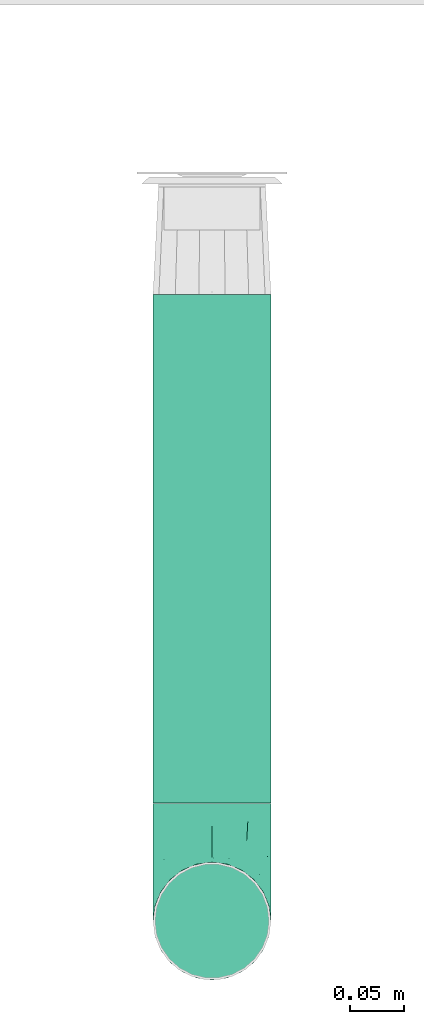
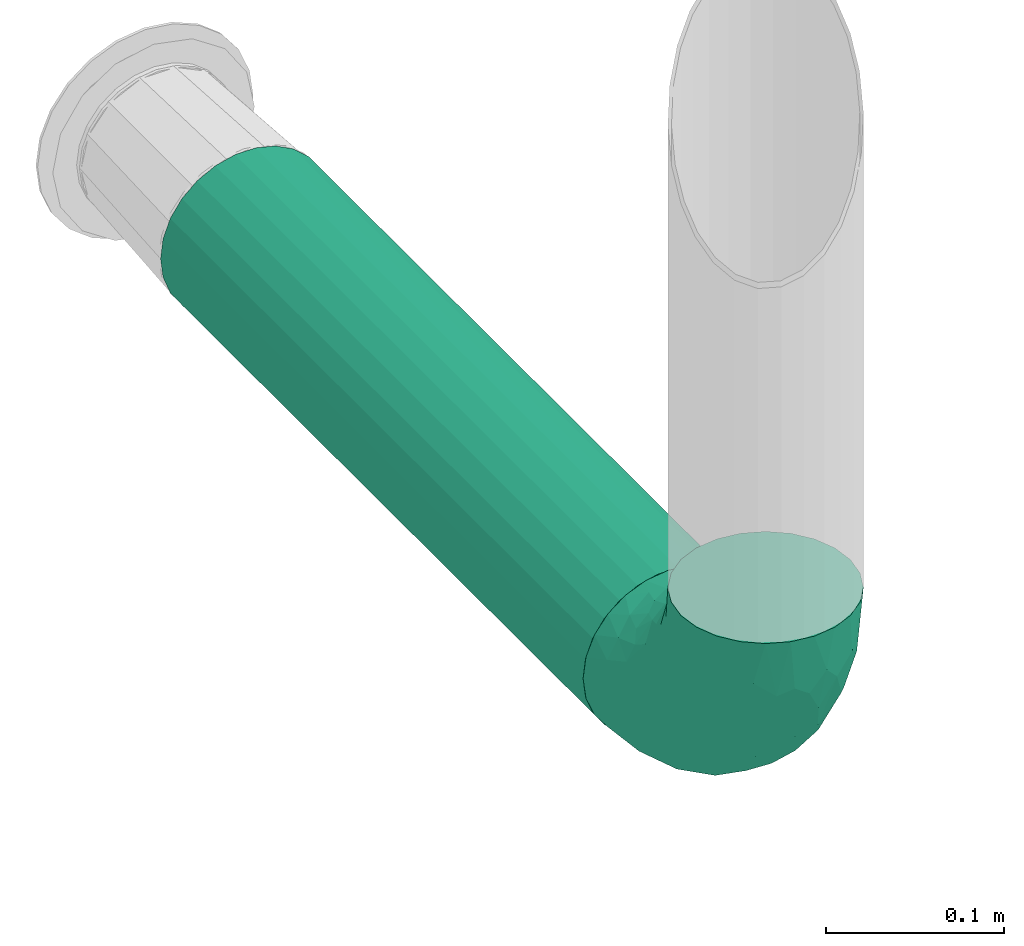
# One storey, part 66 of 123: 1 flow fitting, 1 flow segment.
"""IFC2X3 building model written with IfcOpenShell, lengths in millimetres."""

from ifc_helpers import new_model, entity, si_unit, converted_unit, derived_unit, direction, frame, origin_with_axes, origin_2d_with_axis, place, context, subcontext, project, spatial, hollow_circle, extrude, open_shell, surface_model, source, transform, mapped, material, layer, layer_set, layer_usage, type_object, element, save


model = new_model("IFC2X3")

# Units and contexts
model_context = context("Model", 3, precision=1e-05, world=origin_with_axes(), true_north=direction((0.0, 1.0)))
body_context = subcontext(model_context, "Body", "Model", "MODEL_VIEW")
ifc_project = project(units=[si_unit("AREAUNIT", "SQUARE_METRE"), si_unit("VOLUMEUNIT", "CUBIC_METRE", prefix="DECI"), si_unit("TIMEUNIT", "SECOND"), si_unit("THERMODYNAMICTEMPERATUREUNIT", "DEGREE_CELSIUS"), si_unit("PRESSUREUNIT", "PASCAL"), si_unit("MASSUNIT", "GRAM", prefix="KILO"), si_unit("LENGTHUNIT", "METRE", prefix="MILLI"), si_unit("POWERUNIT", "WATT"), si_unit("ELECTRICCURRENTUNIT", "AMPERE"), si_unit("ELECTRICVOLTAGEUNIT", "VOLT"), derived_unit("VOLUMETRICFLOWRATEUNIT", [(si_unit("VOLUMEUNIT", "CUBIC_METRE", prefix="DECI"), 1), (si_unit("TIMEUNIT", "SECOND"), -1)]), derived_unit("LINEARVELOCITYUNIT", [(si_unit("LENGTHUNIT", "METRE"), 1), (si_unit("TIMEUNIT", "SECOND"), -1)]), derived_unit("MASSDENSITYUNIT", [(si_unit("MASSUNIT", "GRAM", prefix="KILO"), 1), (si_unit("VOLUMEUNIT", "CUBIC_METRE"), -1)]), converted_unit("PLANEANGLEUNIT", "DEGREE", entity("IfcRatioMeasure", 0.01745), si_unit("PLANEANGLEUNIT", "RADIAN"), dimensions=[0, 0, 0, 0, 0, 0, 0])], contexts=[model_context])

# Site, building, storey
site_placement = place(None, origin_with_axes())
site = spatial("IfcSite", under=ifc_project, at=site_placement, CompositionType="ELEMENT")
building_placement = place(site_placement, origin_with_axes())
building = spatial("IfcBuilding", under=site, at=building_placement, Name="mc-building", CompositionType="ELEMENT")
storey_placement = place(building_placement, origin_with_axes())
storey = spatial("IfcBuildingStorey", under=building, at=storey_placement, Name="1. Korrus", CompositionType="ELEMENT", Elevation=0.0)

# Flow fitting
duct_fitting_type = type_object("IfcDuctFittingType", Name="BU", PredefinedType="BEND")
shared_shape_1 = source(origin_with_axes(), body_context, "Body", "SurfaceModel", [
    surface_model("IfcShellBasedSurfaceModel", [(-110.0, -38.89087, -38.89087), (-110.0, -55.0, 0.0), (-110.0, -27.5, -47.63139), (-110.0, -53.12592, -14.23505), (-110.0, -47.63139, -27.5), (-110.0, 47.63139, -27.5), (-110.0, 53.12592, 14.23505), (-110.0, 53.12592, -14.23505), (-110.0, -14.23505, -53.12592), (-110.0, 0.0, -55.0), (-110.0, 38.89087, -38.89087), (-110.0, 27.5, -47.63139), (-110.0, 14.23505, -53.12592), (-110.0, 55.0, 0.0), (-110.0, -53.12592, 14.23505), (-110.0, -47.63139, 27.5), (-110.0, -38.89087, 38.89087), (-110.0, 0.0, 55.0), (-110.0, -27.5, 47.63139), (-110.0, -14.23505, 53.12592), (-110.0, 38.89087, 38.89087), (-110.0, 47.63139, 27.5), (-110.0, 27.5, 47.63139), (-110.0, 14.23505, 53.12592), (0.0, -110.0, -55.0), (14.23505, -110.0, -53.12592), (-14.23505, -110.0, -53.12592), (-53.12592, -110.0, 14.23505), (-27.5, -110.0, -47.63139), (-47.63139, -110.0, -27.5), (-38.89087, -110.0, -38.89087), (55.0, -110.0, 0.0), (53.12592, -110.0, 14.23505), (38.89087, -110.0, -38.89087), (27.5, -110.0, -47.63139), (53.12592, -110.0, -14.23505), (47.63139, -110.0, -27.5), (-53.12592, -110.0, -14.23505), (-47.63139, -110.0, 27.5), (-38.89087, -110.0, 38.89087), (14.23505, -110.0, 53.12592), (-27.5, -110.0, 47.63139), (-14.23505, -110.0, 53.12592), (47.63139, -110.0, 27.5), (38.89087, -110.0, 38.89087), (27.5, -110.0, 47.63139), (0.0, -110.0, 55.0), (-55.0, -110.0, 0.0), (-60.44912, -32.56953, 51.94617), (-76.6405, -38.18013, 45.55988), (-64.21732, -48.68956, 43.63444), (-90.15553, -11.94394, 54.09138), (-76.00813, -5.38378, 55.0), (-70.18771, -18.55163, 54.03432), (-78.5998, -26.77405, 50.81338), (-93.27622, -45.77614, 33.48188), (-75.55424, -54.2118, 32.41257), (-96.12334, -22.13664, 50.81337), (-32.04182, -59.64019, 52.24446), (-18.36258, -70.48427, 54.04484), (-21.00813, -45.34362, 55.0), (-63.60674, -66.07878, 29.97482), (-74.66383, -63.08407, 19.92123), (-63.88653, -74.77858, 17.99134), (-93.11138, -56.59448, 10.50359), (-99.597, -52.72185, 18.52927), (-98.21577, -57.34403, 0.0), (-53.42855, -92.60092, 21.04759), (-88.54852, -54.8376, 21.04759), (-5.38378, -76.00813, 55.0), (-11.86161, -90.23965, 54.10313), (-56.64619, -93.12774, 10.22088), (-57.34403, -98.21577, 0.0), (-44.60838, -44.60838, 52.13415), (-45.34362, -21.00813, 55.0), (-92.68484, -35.46673, 43.63443), (-22.25266, -95.40765, 50.81337), (-27.23711, -77.39884, 50.81337), (-43.70931, -69.58671, 44.47149), (-35.97783, -90.61597, 43.63443), (-58.67786, -84.31125, 16.04456), (-57.2828, -79.3123, 24.9774), (-82.93277, -60.36161, 12.91784), (-49.88337, -54.51816, 47.224), (-74.57753, -66.83759, 9.55742), (-45.35812, -94.97281, 33.48188), (-59.18663, -88.95241, 0.0), (-51.517, -78.6292, 33.48188), (-65.14788, -80.03077, 0.0), (-56.45322, -62.06476, 39.63545), (-88.95241, -59.18663, 0.0), (-80.03077, -65.14788, 0.0), (-71.10913, -71.10913, 0.0), (-94.9309, -45.36788, -33.48188), (-93.11358, -56.60141, -10.46614), (-99.64997, -52.79499, -18.30015), (-79.99933, -46.56772, -37.92748), (-90.20425, -36.08686, -43.63443), (-45.34362, -21.00813, -55.0), (-72.75364, -19.68651, -53.60527), (-76.00813, -5.38378, -55.0), (-21.00813, -45.34362, -55.0), (-5.38378, -76.00813, -55.0), (-21.91957, -65.12078, -53.85897), (-35.41876, -92.89265, -43.63443), (-91.10309, -11.02766, -54.21832), (-45.77614, -93.27622, -33.48188), (-90.50474, -23.21022, -50.81337), (-70.92854, -33.31794, -49.51754), (-78.52933, -63.35627, -11.73997), (-24.91508, -84.05606, -50.81337), (-88.78941, -54.74452, -21.04759), (-63.49062, -67.59111, -28.46929), (-73.36422, -62.46673, -22.94182), (-69.59921, -57.34866, -33.48187), (-56.59448, -93.11138, -10.50359), (-54.10679, -75.85581, -32.31867), (-54.8376, -88.54852, -21.04759), (-57.75956, -31.09612, -52.80882), (-52.72185, -99.597, -18.52927), (-12.62913, -89.46304, -53.99097), (-34.46825, -66.46123, -50.04329), (-43.9837, -43.9837, -52.42279), (-65.78527, -72.58348, -17.68796), (-57.47001, -51.99467, -44.91465), (-70.34468, -43.65295, -44.21951), (-60.72547, -82.29174, -12.88567), (-42.34915, -74.24548, -43.63444), (-57.25194, -63.5016, -38.08211), (-80.95344, -53.56991, -29.32027), (-52.32891, -4.55257, -54.0482), (14.95561, -36.05775, -42.26543), (14.88266, -20.92917, -33.7947), (32.52942, -47.13398, -30.48571), (19.3559, -65.35825, -48.00507), (30.24048, -70.09027, -41.7461), (-28.49299, 30.5778, -16.4009), (-47.13398, 32.52942, -30.48571), (-70.35075, 46.44478, -19.5952), (-22.4954, -22.4954, -53.25347), (-4.55257, -52.32891, -54.0482), (-75.47368, 11.22546, -52.60718), (-81.32209, 51.5606, -9.98467), (-70.09027, 30.24048, -41.7461), (-80.81763, 41.84862, -32.14655), (-9.15831, 10.852, -27.8997), (-36.05774, 14.95561, -42.26543), (-65.35825, 19.3559, -48.00507), (3.94376, -43.9333, -50.53315), (11.22546, -75.47368, -52.60718), (-43.9333, 3.94376, -50.53315), (-13.39742, -13.39743, -48.13058), (50.20582, -74.51695, -9.9731), (41.8609, -47.82256, -9.92641), (49.37776, -67.29486, 0.0), (18.93131, -11.7156, -17.56239), (-1.23348, 12.25375, -12.18106), (-27.5, 32.89419, 0.0), (41.84862, -80.81763, -32.14655), (46.44478, -70.35075, -19.5952), (35.70604, -41.31408, -20.38235), (6.67262, 6.67262, 0.0), (32.89419, -27.5, 0.0), (-50.36265, 42.95545, -9.51562), (-67.29486, 49.37776, 0.0), (-5.47251, -5.47251, -39.92906), (-70.35075, 46.44478, 19.5952), (-74.51695, 50.20582, 9.9731), (-47.13398, 32.52942, 30.48571), (-41.31407, 35.70604, 20.38235), (-80.81763, 41.84862, 32.14655), (11.22546, -75.47368, 52.60718), (-4.55257, -52.32891, 54.0482), (-36.05774, 14.95561, 42.26543), (-65.35825, 19.3559, 48.00507), (-43.9333, 3.94376, 50.53315), (-70.09027, 30.24048, 41.7461), (-11.7156, 18.93131, 17.56239), (12.25375, -1.23348, 12.18106), (30.5778, -28.49299, 16.4009), (42.95545, -50.36265, 9.51562), (51.5606, -81.32209, 9.98467), (-52.32891, -4.55257, 54.0482), (-75.47368, 11.22546, 52.60718), (-13.39742, -13.39743, 48.13058), (-22.4954, -22.4954, 53.25347), (3.94376, -43.9333, 50.53315), (-20.92916, 14.88266, 33.79469), (10.852, -9.15831, 27.8997), (-47.82256, 41.8609, 9.92641), (32.52942, -47.13398, 30.48571), (46.44478, -70.35075, 19.5952), (41.84862, -80.81763, 32.14655), (14.95561, -36.05775, 42.26543), (19.3559, -65.35825, 48.00507), (30.24048, -70.09027, 41.7461), (-5.47251, -5.47251, 39.92906)], [open_shell([[[0, 1, 2]], [[3, 1, 4]], [[5, 6, 7]], [[8, 1, 9]], [[2, 1, 8]], [[4, 1, 0]], [[10, 9, 6]], [[9, 10, 11]], [[11, 12, 9]], [[6, 5, 10]], [[7, 6, 13]], [[14, 15, 9]], [[9, 15, 16]], [[17, 16, 18]], [[9, 16, 17]], [[19, 17, 18]], [[9, 20, 21]], [[6, 9, 21]], [[9, 22, 20]], [[23, 22, 9]], [[17, 23, 9]], [[9, 1, 14]], [[24, 25, 26]], [[26, 27, 28]], [[29, 30, 27]], [[28, 27, 30]], [[26, 31, 32]], [[33, 31, 34]], [[25, 34, 31]], [[35, 31, 36]], [[33, 36, 31]], [[31, 26, 25]], [[29, 27, 37]], [[38, 27, 26]], [[39, 38, 26]], [[40, 41, 26]], [[41, 39, 26]], [[40, 42, 41]], [[43, 44, 26]], [[43, 26, 32]], [[44, 45, 26]], [[26, 45, 40]], [[40, 46, 42]], [[47, 37, 27]], [[48, 49, 50]], [[51, 52, 17]], [[48, 53, 54]], [[49, 55, 56]], [[16, 15, 55]], [[18, 57, 19]], [[58, 59, 60]], [[61, 62, 63]], [[64, 65, 14]], [[53, 51, 54]], [[66, 64, 14]], [[27, 38, 67]], [[65, 68, 55]], [[68, 65, 64]], [[69, 59, 70]], [[71, 72, 27]], [[73, 60, 74]], [[55, 49, 75]], [[42, 70, 76]], [[51, 57, 54]], [[77, 78, 79]], [[42, 76, 41]], [[46, 70, 42]], [[55, 68, 56]], [[75, 18, 16]], [[77, 79, 76]], [[80, 67, 81]], [[68, 82, 62]], [[83, 78, 58]], [[82, 84, 62]], [[39, 79, 85]], [[71, 67, 80]], [[72, 71, 86]], [[67, 85, 87]], [[88, 80, 63]], [[39, 41, 79]], [[87, 79, 78]], [[55, 75, 16]], [[50, 89, 83]], [[38, 39, 85]], [[56, 68, 62]], [[61, 87, 89]], [[48, 50, 83]], [[18, 75, 57]], [[54, 75, 49]], [[38, 85, 67]], [[85, 79, 87]], [[56, 62, 61]], [[50, 56, 89]], [[87, 61, 81]], [[90, 64, 66]], [[14, 1, 66]], [[91, 92, 84]], [[82, 90, 91]], [[90, 82, 64]], [[62, 84, 63]], [[84, 82, 91]], [[64, 82, 68]], [[65, 15, 14]], [[15, 65, 55]], [[72, 47, 27]], [[86, 71, 80]], [[67, 71, 27]], [[88, 63, 92]], [[63, 80, 81]], [[63, 81, 61]], [[87, 81, 67]], [[41, 76, 79]], [[70, 59, 77]], [[76, 70, 77]], [[69, 70, 46]], [[77, 59, 58]], [[59, 69, 60]], [[77, 58, 78]], [[73, 58, 60]], [[19, 57, 51]], [[54, 57, 75]], [[19, 51, 17]], [[53, 52, 51]], [[53, 74, 52]], [[73, 74, 48]], [[53, 48, 74]], [[83, 73, 48]], [[73, 83, 58]], [[78, 83, 89]], [[78, 89, 87]], [[61, 89, 56]], [[54, 49, 48]], [[50, 49, 56]], [[88, 86, 80]], [[63, 84, 92]], [[93, 4, 0]], [[66, 94, 90]], [[95, 94, 3]], [[96, 93, 97]], [[98, 99, 100]], [[0, 2, 97]], [[101, 102, 103]], [[104, 28, 30]], [[9, 105, 8]], [[30, 106, 104]], [[107, 105, 99]], [[97, 107, 108]], [[94, 109, 90]], [[2, 8, 107]], [[94, 66, 3]], [[110, 26, 28]], [[94, 111, 109]], [[112, 113, 114]], [[72, 115, 37]], [[116, 106, 117]], [[98, 118, 99]], [[119, 115, 117]], [[115, 119, 37]], [[110, 120, 26]], [[103, 110, 121]], [[117, 106, 119]], [[120, 110, 103]], [[98, 101, 122]], [[117, 123, 116]], [[108, 124, 125]], [[126, 117, 115]], [[30, 29, 106]], [[120, 102, 24]], [[110, 104, 127]], [[97, 125, 96]], [[118, 122, 124]], [[124, 127, 128]], [[93, 0, 97]], [[86, 126, 115]], [[127, 106, 116]], [[129, 113, 111]], [[4, 93, 95]], [[114, 129, 96]], [[28, 104, 110]], [[127, 104, 106]], [[2, 107, 97]], [[108, 107, 99]], [[118, 108, 99]], [[100, 99, 105]], [[128, 112, 114]], [[127, 124, 121]], [[66, 1, 3]], [[91, 90, 109]], [[95, 111, 94]], [[109, 123, 92]], [[114, 113, 129]], [[111, 95, 93]], [[95, 3, 4]], [[86, 115, 72]], [[37, 47, 72]], [[88, 92, 123]], [[123, 117, 126]], [[126, 88, 123]], [[88, 126, 86]], [[119, 29, 37]], [[29, 119, 106]], [[111, 93, 129]], [[124, 114, 125]], [[100, 105, 9]], [[8, 105, 107]], [[108, 118, 124]], [[122, 118, 98]], [[96, 129, 93]], [[109, 111, 113]], [[113, 123, 109]], [[116, 123, 112]], [[113, 112, 123]], [[116, 112, 128]], [[116, 128, 127]], [[124, 128, 114]], [[103, 122, 101]], [[127, 121, 110]], [[121, 122, 103]], [[122, 121, 124]], [[26, 120, 24]], [[102, 120, 103]], [[108, 125, 97]], [[109, 92, 91]], [[96, 125, 114]], [[100, 130, 98]], [[131, 132, 133]], [[134, 135, 34]], [[136, 137, 138]], [[101, 139, 140]], [[9, 141, 100]], [[138, 7, 142]], [[137, 143, 144]], [[142, 7, 13]], [[145, 146, 137]], [[146, 147, 143]], [[5, 138, 144]], [[7, 138, 5]], [[5, 144, 10]], [[140, 148, 149]], [[143, 11, 10]], [[147, 12, 11]], [[100, 141, 130]], [[98, 139, 101]], [[148, 134, 149]], [[139, 150, 151]], [[152, 153, 154]], [[150, 139, 130]], [[25, 24, 149]], [[141, 12, 147]], [[132, 145, 155]], [[156, 136, 157]], [[158, 33, 135]], [[148, 139, 151]], [[36, 33, 158]], [[34, 135, 33]], [[159, 160, 153]], [[160, 159, 133]], [[137, 146, 143]], [[152, 154, 31]], [[137, 136, 145]], [[161, 162, 155]], [[133, 159, 158]], [[134, 148, 131]], [[163, 164, 157]], [[163, 142, 164]], [[102, 101, 140]], [[162, 154, 153]], [[159, 35, 36]], [[155, 156, 161]], [[131, 165, 132]], [[155, 145, 156]], [[98, 130, 139]], [[150, 130, 141]], [[147, 150, 141]], [[9, 12, 141]], [[149, 24, 102]], [[148, 140, 139]], [[140, 149, 102]], [[34, 25, 134]], [[146, 151, 150]], [[143, 147, 11]], [[147, 146, 150]], [[145, 165, 146]], [[25, 149, 134]], [[135, 134, 131]], [[135, 131, 133]], [[151, 165, 131]], [[148, 151, 131]], [[165, 151, 146]], [[160, 133, 132]], [[132, 165, 145]], [[36, 158, 159]], [[133, 158, 135]], [[10, 144, 143]], [[137, 144, 138]], [[162, 153, 155]], [[159, 153, 152]], [[160, 155, 153]], [[155, 160, 132]], [[152, 35, 159]], [[35, 152, 31]], [[136, 138, 163]], [[164, 142, 13]], [[142, 163, 138]], [[136, 163, 157]], [[161, 156, 157]], [[136, 156, 145]], [[166, 6, 21]], [[167, 164, 13]], [[166, 168, 169]], [[170, 168, 166]], [[69, 171, 172]], [[173, 174, 175]], [[174, 176, 22]], [[161, 157, 177]], [[170, 20, 176]], [[21, 20, 170]], [[178, 179, 162]], [[180, 181, 154]], [[182, 175, 183]], [[183, 23, 17]], [[184, 185, 186]], [[74, 185, 182]], [[52, 74, 182]], [[187, 188, 177]], [[166, 169, 189]], [[190, 179, 188]], [[22, 176, 20]], [[180, 154, 162]], [[32, 191, 43]], [[192, 44, 43]], [[43, 191, 192]], [[32, 31, 181]], [[193, 194, 195]], [[194, 40, 45]], [[190, 193, 195]], [[45, 44, 195]], [[69, 46, 171]], [[74, 60, 185]], [[157, 164, 189]], [[167, 189, 164]], [[172, 60, 69]], [[185, 172, 186]], [[173, 187, 168]], [[191, 32, 181]], [[190, 195, 192]], [[179, 190, 191]], [[175, 174, 183]], [[171, 40, 194]], [[188, 193, 190]], [[175, 185, 184]], [[177, 178, 161]], [[173, 196, 187]], [[177, 188, 178]], [[60, 172, 185]], [[186, 172, 171]], [[194, 186, 171]], [[46, 40, 171]], [[183, 17, 52]], [[175, 182, 185]], [[182, 183, 52]], [[22, 23, 174]], [[193, 184, 186]], [[195, 194, 45]], [[194, 193, 186]], [[188, 196, 193]], [[23, 183, 174]], [[176, 174, 173]], [[176, 173, 168]], [[184, 196, 173]], [[175, 184, 173]], [[196, 184, 193]], [[169, 168, 187]], [[187, 196, 188]], [[21, 170, 166]], [[168, 170, 176]], [[44, 192, 195]], [[190, 192, 191]], [[157, 189, 177]], [[166, 189, 167]], [[169, 177, 189]], [[177, 169, 187]], [[167, 6, 166]], [[6, 167, 13]], [[179, 191, 180]], [[154, 181, 31]], [[181, 180, 191]], [[179, 180, 162]], [[161, 178, 162]], [[179, 178, 188]]])]),
])
flow_fitting_placement = place(storey_placement, frame((19148.85991, -687.64676, 2300.0), z_axis=(1.0, 0.0, 0.0), x_axis=(0.0, -1.0, 0.0)))
element("IfcFlowFitting", 1, at=flow_fitting_placement, inside=storey, type_object=duct_fitting_type, Name="BU", context=body_context, shape_type="MappedRepresentation", body=[
    mapped(shared_shape_1, transform((0.0, 0.0, 0.0), scale=1.0)),
])

# Flow segment
ifc_material = material(Name="FZ1")
ifc_layer = layer(ifc_material, 0.0)
ifc_layer_set = layer_set([ifc_layer], Name="FZ1")
ifc_layer_usage = layer_usage(ifc_layer_set, "AXIS1", "POSITIVE", 0.0)
duct_segment_type = type_object("IfcDuctSegmentType", PredefinedType="RIGIDSEGMENT")
shared_shape_2 = source(origin_with_axes(), body_context, "Body", "SweptSolid", [
    extrude(hollow_circle(Radius=55.0, WallThickness=2.0, at=origin_2d_with_axis()), frame((0.0, 0.0, 0.0), z_axis=(1.0, 0.0, 0.0), x_axis=(0.0, 1.0, 0.0)), (0.0, 0.0, 1.0), 475.2),
])
flow_segment_placement = place(storey_placement, frame((19148.85991, -102.39828, 2300.0), z_axis=(0.0, 0.0, 1.0), x_axis=(0.0, -1.0, 0.0)))
element("IfcFlowSegment", 2, at=flow_segment_placement, inside=storey, type_object=duct_segment_type, material=ifc_layer_usage, context=body_context, shape_type="MappedRepresentation", body=[
    mapped(shared_shape_2, transform((0.0, 0.0, 0.0), scale=1.0)),
])

save(model, "model.ifc")
